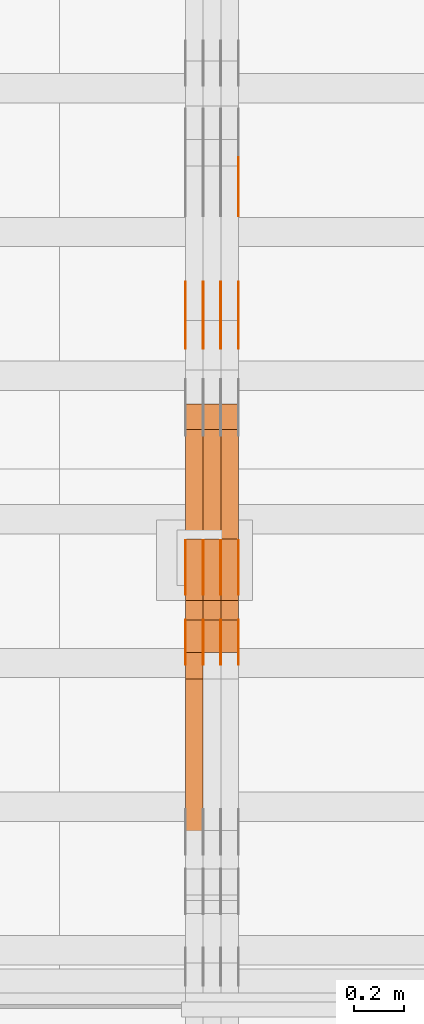
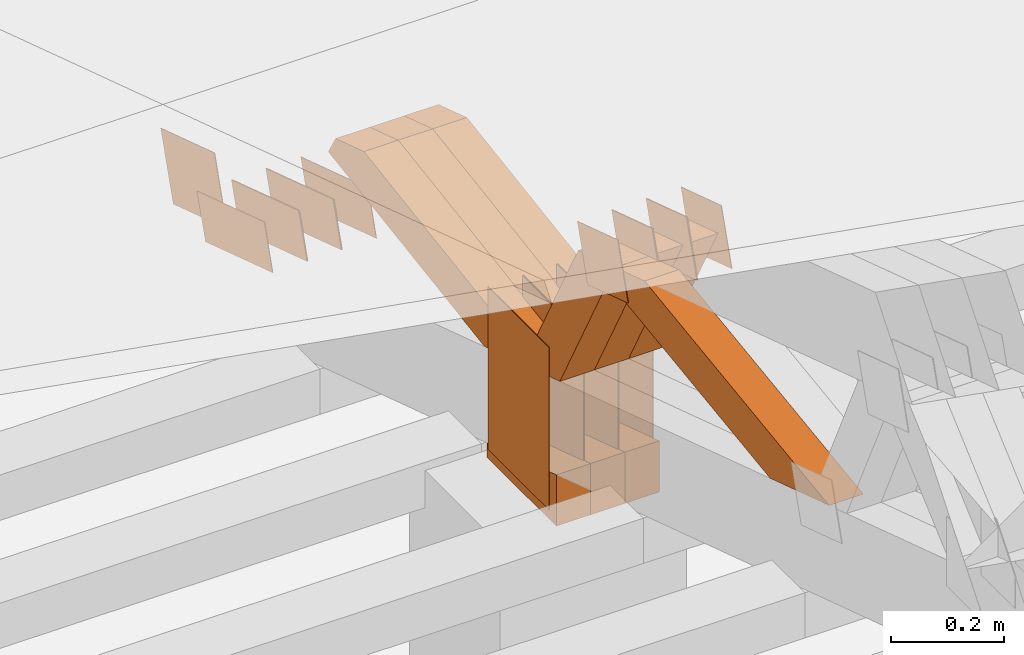
# One storey, part 287 of 385: 29 proxies.
"""IFC2X3 building model written with IfcOpenShell, lengths in millimetres."""

from ifc_helpers import new_model, entity, si_unit, converted_unit, derived_unit, direction, frame, origin, origin_2d_with_axis, place, context, subcontext, project, spatial, polyline, rectangle, outline, extrude, source, transform, mapped, material, type_object, type_shapes, element, save


model = new_model("IFC2X3")

# Units and contexts
model_context = context("Model", 3, precision=0.01, world=origin(), true_north=direction((6.12303176911189e-17, 1.0)))
body_context = subcontext(model_context, "Body", "Model", "MODEL_VIEW")
ifc_project = project(units=[si_unit("LENGTHUNIT", "METRE", prefix="MILLI"), si_unit("AREAUNIT", "SQUARE_METRE"), si_unit("VOLUMEUNIT", "CUBIC_METRE"), converted_unit("PLANEANGLEUNIT", "DEGREE", entity("IfcRatioMeasure", 0.0174532925199433), si_unit("PLANEANGLEUNIT", "RADIAN"), dimensions=[0, 0, 0, 0, 0, 0, 0]), si_unit("MASSUNIT", "GRAM", prefix="KILO"), derived_unit("MASSDENSITYUNIT", [(si_unit("MASSUNIT", "GRAM", prefix="KILO"), 1), (si_unit("LENGTHUNIT", "METRE"), -3)]), si_unit("TIMEUNIT", "SECOND"), si_unit("FREQUENCYUNIT", "HERTZ"), si_unit("THERMODYNAMICTEMPERATUREUNIT", "DEGREE_CELSIUS"), derived_unit("THERMALTRANSMITTANCEUNIT", [(si_unit("MASSUNIT", "GRAM", prefix="KILO"), 1), (si_unit("THERMODYNAMICTEMPERATUREUNIT", "KELVIN"), -1), (si_unit("TIMEUNIT", "SECOND"), -3)]), derived_unit("VOLUMETRICFLOWRATEUNIT", [(si_unit("LENGTHUNIT", "METRE"), 3), (si_unit("TIMEUNIT", "SECOND"), -1)]), si_unit("ELECTRICCURRENTUNIT", "AMPERE"), si_unit("ELECTRICVOLTAGEUNIT", "VOLT"), si_unit("POWERUNIT", "WATT"), si_unit("FORCEUNIT", "NEWTON", prefix="KILO"), si_unit("ILLUMINANCEUNIT", "LUX"), si_unit("LUMINOUSFLUXUNIT", "LUMEN"), si_unit("LUMINOUSINTENSITYUNIT", "CANDELA"), derived_unit("USERDEFINED", [(si_unit("MASSUNIT", "GRAM", prefix="KILO"), -1), (si_unit("LENGTHUNIT", "METRE"), -2), (si_unit("TIMEUNIT", "SECOND"), 3), (si_unit("LUMINOUSFLUXUNIT", "LUMEN"), 1)]), derived_unit("LINEARVELOCITYUNIT", [(si_unit("LENGTHUNIT", "METRE"), 1), (si_unit("TIMEUNIT", "SECOND"), -1)]), si_unit("PRESSUREUNIT", "PASCAL"), derived_unit("USERDEFINED", [(si_unit("LENGTHUNIT", "METRE"), -2), (si_unit("MASSUNIT", "GRAM", prefix="KILO"), 1), (si_unit("TIMEUNIT", "SECOND"), -2)])], contexts=[model_context])

# Site, building, storey
site_placement = place(None, origin())
site = spatial("IfcSite", under=ifc_project, at=site_placement, CompositionType="ELEMENT")
building_placement = place(site_placement, origin())
building = spatial("IfcBuilding", under=site, at=building_placement, CompositionType="ELEMENT")
storey_placement = place(building_placement, origin())
storey = spatial("IfcBuildingStorey", under=building, at=storey_placement, Name="Default", CompositionType="ELEMENT", Elevation=0.0)

# Proxies
ifc_material_1 = material(Name="IfcSurfaceStyle #411286")
building_element_proxy_type_1 = type_object("IfcBuildingElementProxyType", PredefinedType="NOTDEFINED", material=ifc_material_1)
shared_shape_1 = source(origin(), body_context, "Body", "SweptSolid", [
    extrude(outline(polyline([(-125.00031378339, -47.9999612158856), (125.000225258022, -47.9999612158856), (124.999811678525, 47.9999612158856), (-124.999723153156, 47.9999612158856), (-125.00031378339, -47.9999612158856)])), frame((125.000225258022, 48.0000091013474, 0.0), z_axis=(0.0, 0.0, 1.0), x_axis=(-1.0, 0.0, 0.0)), (0.0, 0.0, 1.0), 1.3),
])
type_shapes(building_element_proxy_type_1, [shared_shape_1])
proxy_1_placement = place(building_placement, frame((33386.3, 18456.8597683375, 2657.46691321253), z_axis=(-1.0, 0.0, 0.0), x_axis=(0.0, -0.951056516295124, 0.309016994375039)))
element("IfcBuildingElementProxy", 1, at=proxy_1_placement, inside=storey, type_object=building_element_proxy_type_1, material=ifc_material_1, context=body_context, shape_type="MappedRepresentation", body=[
    mapped(shared_shape_1, transform((0.0, 0.0, 0.0), scale=1.0)),
])
ifc_material_2 = material(Name="IfcSurfaceStyle #411229")
building_element_proxy_type_2 = type_object("IfcBuildingElementProxyType", PredefinedType="NOTDEFINED", material=ifc_material_2)
shared_shape_2 = source(origin(), body_context, "Body", "SweptSolid", [
    extrude(outline(polyline([(-125.00031378339, -47.9999612158856), (125.000225258022, -47.9999612158856), (124.999811678525, 47.9999612158856), (-124.999723153156, 47.9999612158856), (-125.00031378339, -47.9999612158856)])), frame((125.000225258022, 48.0000091013474, 0.0), z_axis=(0.0, 0.0, 1.0), x_axis=(-1.0, 0.0, 0.0)), (0.0, 0.0, 1.0), 1.3),
])
type_shapes(building_element_proxy_type_2, [shared_shape_2])
proxy_2_placement = place(building_placement, frame((33315.0, 18456.8597683375, 2657.46691321253), z_axis=(-1.0, 0.0, 0.0), x_axis=(0.0, -0.951056516295124, 0.309016994375039)))
element("IfcBuildingElementProxy", 2, at=proxy_2_placement, inside=storey, type_object=building_element_proxy_type_2, material=ifc_material_2, context=body_context, shape_type="MappedRepresentation", body=[
    mapped(shared_shape_2, transform((0.0, 0.0, 0.0), scale=1.0)),
])
ifc_material_3 = material(Name="IfcSurfaceStyle #411172")
building_element_proxy_type_3 = type_object("IfcBuildingElementProxyType", PredefinedType="NOTDEFINED", material=ifc_material_3)
shared_shape_3 = source(origin(), body_context, "Body", "SweptSolid", [
    extrude(outline(polyline([(-125.00031378339, -47.9999612158856), (125.000225258022, -47.9999612158856), (124.999811678525, 47.9999612158856), (-124.999723153156, 47.9999612158856), (-125.00031378339, -47.9999612158856)])), frame((125.000225258022, 48.0000091013474, 0.0), z_axis=(0.0, 0.0, 1.0), x_axis=(-1.0, 0.0, 0.0)), (0.0, 0.0, 1.0), 1.3),
])
type_shapes(building_element_proxy_type_3, [shared_shape_3])
proxy_3_placement = place(building_placement, frame((33316.3, 18456.8597683375, 2657.46691321253), z_axis=(-1.0, 0.0, 0.0), x_axis=(0.0, -0.951056516295124, 0.309016994375039)))
element("IfcBuildingElementProxy", 3, at=proxy_3_placement, inside=storey, type_object=building_element_proxy_type_3, material=ifc_material_3, context=body_context, shape_type="MappedRepresentation", body=[
    mapped(shared_shape_3, transform((0.0, 0.0, 0.0), scale=1.0)),
])
ifc_material_4 = material(Name="IfcSurfaceStyle #411115")
building_element_proxy_type_4 = type_object("IfcBuildingElementProxyType", PredefinedType="NOTDEFINED", material=ifc_material_4)
shared_shape_4 = source(origin(), body_context, "Body", "SweptSolid", [
    extrude(outline(polyline([(-125.00031378339, -47.9999612158856), (125.000225258022, -47.9999612158856), (124.999811678525, 47.9999612158856), (-124.999723153156, 47.9999612158856), (-125.00031378339, -47.9999612158856)])), frame((125.000225258022, 48.0000091013474, 0.0), z_axis=(0.0, 0.0, 1.0), x_axis=(-1.0, 0.0, 0.0)), (0.0, 0.0, 1.0), 1.29999999999998),
])
type_shapes(building_element_proxy_type_4, [shared_shape_4])
proxy_4_placement = place(building_placement, frame((33245.0, 18456.8597683375, 2657.46691321253), z_axis=(-1.0, 0.0, 0.0), x_axis=(0.0, -0.951056516295124, 0.309016994375039)))
element("IfcBuildingElementProxy", 4, at=proxy_4_placement, inside=storey, type_object=building_element_proxy_type_4, material=ifc_material_4, context=body_context, shape_type="MappedRepresentation", body=[
    mapped(shared_shape_4, transform((0.0, 0.0, 0.0), scale=1.0)),
])
ifc_material_5 = material(Name="IfcSurfaceStyle #411058")
building_element_proxy_type_5 = type_object("IfcBuildingElementProxyType", PredefinedType="NOTDEFINED", material=ifc_material_5)
shared_shape_5 = source(origin(), body_context, "Body", "SweptSolid", [
    extrude(outline(polyline([(-125.00031378339, -47.9999612158856), (125.000225258022, -47.9999612158856), (124.999811678525, 47.9999612158856), (-124.999723153156, 47.9999612158856), (-125.00031378339, -47.9999612158856)])), frame((125.000225258022, 48.0000091013474, 0.0), z_axis=(0.0, 0.0, 1.0), x_axis=(-1.0, 0.0, 0.0)), (0.0, 0.0, 1.0), 1.29999999999998),
])
type_shapes(building_element_proxy_type_5, [shared_shape_5])
proxy_5_placement = place(building_placement, frame((33246.3, 18456.8597683375, 2657.46691321253), z_axis=(-1.0, 0.0, 0.0), x_axis=(0.0, -0.951056516295124, 0.309016994375039)))
element("IfcBuildingElementProxy", 5, at=proxy_5_placement, inside=storey, type_object=building_element_proxy_type_5, material=ifc_material_5, context=body_context, shape_type="MappedRepresentation", body=[
    mapped(shared_shape_5, transform((0.0, 0.0, 0.0), scale=1.0)),
])
ifc_material_6 = material(Name="IfcSurfaceStyle #411001")
building_element_proxy_type_6 = type_object("IfcBuildingElementProxyType", PredefinedType="NOTDEFINED", material=ifc_material_6)
shared_shape_6 = source(origin(), body_context, "Body", "SweptSolid", [
    extrude(outline(polyline([(-125.00031378339, -47.9999612158856), (125.000225258022, -47.9999612158856), (124.999811678525, 47.9999612158856), (-124.999723153156, 47.9999612158856), (-125.00031378339, -47.9999612158856)])), frame((125.000225258022, 48.0000091013474, 0.0), z_axis=(0.0, 0.0, 1.0), x_axis=(-1.0, 0.0, 0.0)), (0.0, 0.0, 1.0), 1.29999999999998),
])
type_shapes(building_element_proxy_type_6, [shared_shape_6])
proxy_6_placement = place(building_placement, frame((33175.0, 18456.8597683375, 2657.46691321253), z_axis=(-1.0, 0.0, 0.0), x_axis=(0.0, -0.951056516295124, 0.309016994375039)))
element("IfcBuildingElementProxy", 6, at=proxy_6_placement, inside=storey, type_object=building_element_proxy_type_6, material=ifc_material_6, context=body_context, shape_type="MappedRepresentation", body=[
    mapped(shared_shape_6, transform((0.0, 0.0, 0.0), scale=1.0)),
])
ifc_material_7 = material(Name="IfcSurfaceStyle #409576")
building_element_proxy_type_7 = type_object("IfcBuildingElementProxyType", PredefinedType="NOTDEFINED", material=ifc_material_7)
shared_shape_7 = source(origin(), body_context, "Body", "SweptSolid", [
    extrude(outline(polyline([(-99.999796294464, -72.0000050220467), (99.9998768370438, -72.0000050220467), (100.000260677528, 72.0000050220467), (-100.000341220108, 72.0000050220467), (-99.999796294464, -72.0000050220467)])), frame((100.000260677528, 72.0000050220467, 0.0), z_axis=(0.0, 0.0, 1.0), x_axis=(-1.0, 0.0, 0.0)), (0.0, 0.0, 1.0), 1.3),
])
type_shapes(building_element_proxy_type_7, [shared_shape_7])
proxy_7_placement = place(building_placement, frame((33386.3, 18936.3876569477, 2373.90613192527), z_axis=(-1.0, 0.0, 0.0), x_axis=(0.0, -0.951056516295124, 0.309016994375039)))
element("IfcBuildingElementProxy", 7, at=proxy_7_placement, inside=storey, type_object=building_element_proxy_type_7, material=ifc_material_7, context=body_context, shape_type="MappedRepresentation", body=[
    mapped(shared_shape_7, transform((0.0, 0.0, 0.0), scale=1.0)),
])
ifc_material_8 = material(Name="IfcSurfaceStyle #409234")
building_element_proxy_type_8 = type_object("IfcBuildingElementProxyType", PredefinedType="NOTDEFINED", material=ifc_material_8)
shared_shape_8 = source(origin(), body_context, "Body", "SweptSolid", [
    extrude(rectangle(XDim=350.0, YDim=215.999999999984, at=origin_2d_with_axis()), frame((175.0, 108.0, 0.0), z_axis=(0.0, 0.0, 1.0), x_axis=(-1.0, 0.0, 0.0)), (0.0, 0.0, 1.0), 1.29999999999999),
])
type_shapes(building_element_proxy_type_8, [shared_shape_8])
proxy_8_placement = place(building_placement, frame((33386.3, 17459.2939453125, 3165.36425781251), z_axis=(-1.0, 0.0, 0.0), x_axis=(0.0, 0.0, -1.0)))
element("IfcBuildingElementProxy", 8, at=proxy_8_placement, inside=storey, type_object=building_element_proxy_type_8, material=ifc_material_8, context=body_context, shape_type="MappedRepresentation", body=[
    mapped(shared_shape_8, transform((0.0, 0.0, 0.0), scale=1.0)),
])
ifc_material_9 = material(Name="IfcSurfaceStyle #409177")
building_element_proxy_type_9 = type_object("IfcBuildingElementProxyType", PredefinedType="NOTDEFINED", material=ifc_material_9)
shared_shape_9 = source(origin(), body_context, "Body", "SweptSolid", [
    extrude(rectangle(XDim=350.0, YDim=215.999999999984, at=origin_2d_with_axis()), frame((175.0, 108.0, 0.0), z_axis=(0.0, 0.0, 1.0), x_axis=(-1.0, 0.0, 0.0)), (0.0, 0.0, 1.0), 1.29999999999999),
])
type_shapes(building_element_proxy_type_9, [shared_shape_9])
proxy_9_placement = place(building_placement, frame((33315.0, 17459.2939453125, 3165.36425781251), z_axis=(-1.0, 0.0, 0.0), x_axis=(0.0, 0.0, -1.0)))
element("IfcBuildingElementProxy", 9, at=proxy_9_placement, inside=storey, type_object=building_element_proxy_type_9, material=ifc_material_9, context=body_context, shape_type="MappedRepresentation", body=[
    mapped(shared_shape_9, transform((0.0, 0.0, 0.0), scale=1.0)),
])
ifc_material_10 = material(Name="IfcSurfaceStyle #409120")
building_element_proxy_type_10 = type_object("IfcBuildingElementProxyType", PredefinedType="NOTDEFINED", material=ifc_material_10)
shared_shape_10 = source(origin(), body_context, "Body", "SweptSolid", [
    extrude(rectangle(XDim=350.0, YDim=215.999999999984, at=origin_2d_with_axis()), frame((175.0, 108.0, 0.0), z_axis=(0.0, 0.0, 1.0), x_axis=(-1.0, 0.0, 0.0)), (0.0, 0.0, 1.0), 1.29999999999999),
])
type_shapes(building_element_proxy_type_10, [shared_shape_10])
proxy_10_placement = place(building_placement, frame((33316.3, 17459.2939453125, 3165.36425781251), z_axis=(-1.0, 0.0, 0.0), x_axis=(0.0, 0.0, -1.0)))
element("IfcBuildingElementProxy", 10, at=proxy_10_placement, inside=storey, type_object=building_element_proxy_type_10, material=ifc_material_10, context=body_context, shape_type="MappedRepresentation", body=[
    mapped(shared_shape_10, transform((0.0, 0.0, 0.0), scale=1.0)),
])
ifc_material_11 = material(Name="IfcSurfaceStyle #409063")
building_element_proxy_type_11 = type_object("IfcBuildingElementProxyType", PredefinedType="NOTDEFINED", material=ifc_material_11)
shared_shape_11 = source(origin(), body_context, "Body", "SweptSolid", [
    extrude(rectangle(XDim=350.0, YDim=215.999999999984, at=origin_2d_with_axis()), frame((175.0, 108.0, 0.0), z_axis=(0.0, 0.0, 1.0), x_axis=(-1.0, 0.0, 0.0)), (0.0, 0.0, 1.0), 1.29999999999998),
])
type_shapes(building_element_proxy_type_11, [shared_shape_11])
proxy_11_placement = place(building_placement, frame((33245.0, 17459.2939453125, 3165.36425781251), z_axis=(-1.0, 0.0, 0.0), x_axis=(0.0, 0.0, -1.0)))
element("IfcBuildingElementProxy", 11, at=proxy_11_placement, inside=storey, type_object=building_element_proxy_type_11, material=ifc_material_11, context=body_context, shape_type="MappedRepresentation", body=[
    mapped(shared_shape_11, transform((0.0, 0.0, 0.0), scale=1.0)),
])
ifc_material_12 = material(Name="IfcSurfaceStyle #409006")
building_element_proxy_type_12 = type_object("IfcBuildingElementProxyType", PredefinedType="NOTDEFINED", material=ifc_material_12)
shared_shape_12 = source(origin(), body_context, "Body", "SweptSolid", [
    extrude(rectangle(XDim=350.0, YDim=215.999999999984, at=origin_2d_with_axis()), frame((175.0, 108.0, 0.0), z_axis=(0.0, 0.0, 1.0), x_axis=(-1.0, 0.0, 0.0)), (0.0, 0.0, 1.0), 1.29999999999998),
])
type_shapes(building_element_proxy_type_12, [shared_shape_12])
proxy_12_placement = place(building_placement, frame((33246.3, 17459.2939453125, 3165.36425781251), z_axis=(-1.0, 0.0, 0.0), x_axis=(0.0, 0.0, -1.0)))
element("IfcBuildingElementProxy", 12, at=proxy_12_placement, inside=storey, type_object=building_element_proxy_type_12, material=ifc_material_12, context=body_context, shape_type="MappedRepresentation", body=[
    mapped(shared_shape_12, transform((0.0, 0.0, 0.0), scale=1.0)),
])
ifc_material_13 = material(Name="IfcSurfaceStyle #408949")
building_element_proxy_type_13 = type_object("IfcBuildingElementProxyType", PredefinedType="NOTDEFINED", material=ifc_material_13)
shared_shape_13 = source(origin(), body_context, "Body", "SweptSolid", [
    extrude(rectangle(XDim=350.0, YDim=215.999999999984, at=origin_2d_with_axis()), frame((175.0, 108.0, 0.0), z_axis=(0.0, 0.0, 1.0), x_axis=(-1.0, 0.0, 0.0)), (0.0, 0.0, 1.0), 1.29999999999998),
])
type_shapes(building_element_proxy_type_13, [shared_shape_13])
proxy_13_placement = place(building_placement, frame((33175.0, 17459.2939453125, 3165.36425781251), z_axis=(-1.0, 0.0, 0.0), x_axis=(0.0, 0.0, -1.0)))
element("IfcBuildingElementProxy", 13, at=proxy_13_placement, inside=storey, type_object=building_element_proxy_type_13, material=ifc_material_13, context=body_context, shape_type="MappedRepresentation", body=[
    mapped(shared_shape_13, transform((0.0, 0.0, 0.0), scale=1.0)),
])
ifc_material_14 = material(Name="IfcSurfaceStyle #405814")
building_element_proxy_type_14 = type_object("IfcBuildingElementProxyType", PredefinedType="NOTDEFINED", material=ifc_material_14)
shared_shape_14 = source(origin(), body_context, "Body", "SweptSolid", [
    extrude(outline(polyline([(-74.9998605591058, -59.9999264677524), (74.999875428623, -59.9999264677524), (74.9998605591068, 59.9999264677524), (-74.9998754286239, 59.9999264677524), (-74.9998605591058, -59.9999264677524)])), frame((75.0002460484325, 60.0000016373508, 0.0), z_axis=(0.0, 0.0, 1.0), x_axis=(-1.0, 0.0, 0.0)), (0.0, 0.0, 1.0), 1.3),
])
type_shapes(building_element_proxy_type_14, [shared_shape_14])
proxy_14_placement = place(building_placement, frame((33386.3, 17107.0599369346, 3383.82825001787), z_axis=(-1.0, 0.0, 0.0), x_axis=(0.0, -0.951056516295154, 0.309016994374948)))
element("IfcBuildingElementProxy", 14, at=proxy_14_placement, inside=storey, type_object=building_element_proxy_type_14, material=ifc_material_14, context=body_context, shape_type="MappedRepresentation", body=[
    mapped(shared_shape_14, transform((0.0, 0.0, 0.0), scale=1.0)),
])
ifc_material_15 = material(Name="IfcSurfaceStyle #405757")
building_element_proxy_type_15 = type_object("IfcBuildingElementProxyType", PredefinedType="NOTDEFINED", material=ifc_material_15)
shared_shape_15 = source(origin(), body_context, "Body", "SweptSolid", [
    extrude(outline(polyline([(-74.9998605591058, -59.9999264677524), (74.999875428623, -59.9999264677524), (74.9998605591068, 59.9999264677524), (-74.9998754286239, 59.9999264677524), (-74.9998605591058, -59.9999264677524)])), frame((75.0002460484325, 60.0000016373508, 0.0), z_axis=(0.0, 0.0, 1.0), x_axis=(-1.0, 0.0, 0.0)), (0.0, 0.0, 1.0), 1.3),
])
type_shapes(building_element_proxy_type_15, [shared_shape_15])
proxy_15_placement = place(building_placement, frame((33315.0, 17107.0599369346, 3383.82825001787), z_axis=(-1.0, 0.0, 0.0), x_axis=(0.0, -0.951056516295154, 0.309016994374948)))
element("IfcBuildingElementProxy", 15, at=proxy_15_placement, inside=storey, type_object=building_element_proxy_type_15, material=ifc_material_15, context=body_context, shape_type="MappedRepresentation", body=[
    mapped(shared_shape_15, transform((0.0, 0.0, 0.0), scale=1.0)),
])
ifc_material_16 = material(Name="IfcSurfaceStyle #405700")
building_element_proxy_type_16 = type_object("IfcBuildingElementProxyType", PredefinedType="NOTDEFINED", material=ifc_material_16)
shared_shape_16 = source(origin(), body_context, "Body", "SweptSolid", [
    extrude(outline(polyline([(-74.9998605591058, -59.9999264677524), (74.999875428623, -59.9999264677524), (74.9998605591068, 59.9999264677524), (-74.9998754286239, 59.9999264677524), (-74.9998605591058, -59.9999264677524)])), frame((75.0002460484325, 60.0000016373508, 0.0), z_axis=(0.0, 0.0, 1.0), x_axis=(-1.0, 0.0, 0.0)), (0.0, 0.0, 1.0), 1.3),
])
type_shapes(building_element_proxy_type_16, [shared_shape_16])
proxy_16_placement = place(building_placement, frame((33316.3, 17107.0599369346, 3383.82825001787), z_axis=(-1.0, 0.0, 0.0), x_axis=(0.0, -0.951056516295154, 0.309016994374948)))
element("IfcBuildingElementProxy", 16, at=proxy_16_placement, inside=storey, type_object=building_element_proxy_type_16, material=ifc_material_16, context=body_context, shape_type="MappedRepresentation", body=[
    mapped(shared_shape_16, transform((0.0, 0.0, 0.0), scale=1.0)),
])
ifc_material_17 = material(Name="IfcSurfaceStyle #405643")
building_element_proxy_type_17 = type_object("IfcBuildingElementProxyType", PredefinedType="NOTDEFINED", material=ifc_material_17)
shared_shape_17 = source(origin(), body_context, "Body", "SweptSolid", [
    extrude(outline(polyline([(-74.9998605591058, -59.9999264677524), (74.999875428623, -59.9999264677524), (74.9998605591068, 59.9999264677524), (-74.9998754286239, 59.9999264677524), (-74.9998605591058, -59.9999264677524)])), frame((75.0002460484325, 60.0000016373508, 0.0), z_axis=(0.0, 0.0, 1.0), x_axis=(-1.0, 0.0, 0.0)), (0.0, 0.0, 1.0), 1.29999999999999),
])
type_shapes(building_element_proxy_type_17, [shared_shape_17])
proxy_17_placement = place(building_placement, frame((33245.0, 17107.0599369346, 3383.82825001787), z_axis=(-1.0, 0.0, 0.0), x_axis=(0.0, -0.951056516295154, 0.309016994374948)))
element("IfcBuildingElementProxy", 17, at=proxy_17_placement, inside=storey, type_object=building_element_proxy_type_17, material=ifc_material_17, context=body_context, shape_type="MappedRepresentation", body=[
    mapped(shared_shape_17, transform((0.0, 0.0, 0.0), scale=1.0)),
])
ifc_material_18 = material(Name="IfcSurfaceStyle #405586")
building_element_proxy_type_18 = type_object("IfcBuildingElementProxyType", PredefinedType="NOTDEFINED", material=ifc_material_18)
shared_shape_18 = source(origin(), body_context, "Body", "SweptSolid", [
    extrude(outline(polyline([(-74.9998605591058, -59.9999264677524), (74.999875428623, -59.9999264677524), (74.9998605591068, 59.9999264677524), (-74.9998754286239, 59.9999264677524), (-74.9998605591058, -59.9999264677524)])), frame((75.0002460484325, 60.0000016373508, 0.0), z_axis=(0.0, 0.0, 1.0), x_axis=(-1.0, 0.0, 0.0)), (0.0, 0.0, 1.0), 1.29999999999999),
])
type_shapes(building_element_proxy_type_18, [shared_shape_18])
proxy_18_placement = place(building_placement, frame((33246.3, 17107.0599369346, 3383.82825001787), z_axis=(-1.0, 0.0, 0.0), x_axis=(0.0, -0.951056516295154, 0.309016994374948)))
element("IfcBuildingElementProxy", 18, at=proxy_18_placement, inside=storey, type_object=building_element_proxy_type_18, material=ifc_material_18, context=body_context, shape_type="MappedRepresentation", body=[
    mapped(shared_shape_18, transform((0.0, 0.0, 0.0), scale=1.0)),
])
ifc_material_19 = material(Name="IfcSurfaceStyle #405529")
building_element_proxy_type_19 = type_object("IfcBuildingElementProxyType", PredefinedType="NOTDEFINED", material=ifc_material_19)
shared_shape_19 = source(origin(), body_context, "Body", "SweptSolid", [
    extrude(outline(polyline([(-74.9998605591058, -59.9999264677524), (74.999875428623, -59.9999264677524), (74.9998605591068, 59.9999264677524), (-74.9998754286239, 59.9999264677524), (-74.9998605591058, -59.9999264677524)])), frame((75.0002460484325, 60.0000016373508, 0.0), z_axis=(0.0, 0.0, 1.0), x_axis=(-1.0, 0.0, 0.0)), (0.0, 0.0, 1.0), 1.29999999999999),
])
type_shapes(building_element_proxy_type_19, [shared_shape_19])
proxy_19_placement = place(building_placement, frame((33175.0, 17107.0599369346, 3383.82825001787), z_axis=(-1.0, 0.0, 0.0), x_axis=(0.0, -0.951056516295154, 0.309016994374948)))
element("IfcBuildingElementProxy", 19, at=proxy_19_placement, inside=storey, type_object=building_element_proxy_type_19, material=ifc_material_19, context=body_context, shape_type="MappedRepresentation", body=[
    mapped(shared_shape_19, transform((0.0, 0.0, 0.0), scale=1.0)),
])
ifc_material_20 = material(Name="IfcSurfaceStyle #397525")
building_element_proxy_type_20 = type_object("IfcBuildingElementProxyType", Name="T1-E1 397523", PredefinedType="NOTDEFINED", material=ifc_material_20)
shared_shape_20 = source(origin(), body_context, "Body", "SweptSolid", [
    extrude(outline(polyline([(4.4675903320374, -122.500000000001), (35.3350219726624, -122.500000000001), (35.3350219726501, 122.500000000001), (-75.1376342773499, 122.500000000001), (4.4675903320374, -122.500000000001)])), frame((35.3350219726624, 122.50000005215, 0.0), z_axis=(0.0, 0.0, 1.0), x_axis=(-1.0, 0.0, 0.0)), (0.0, 0.0, 1.0), 70.0),
])
type_shapes(building_element_proxy_type_20, [shared_shape_20])
proxy_20_placement = place(building_placement, frame((33385.0, 17220.0, 2794.30932617186), z_axis=(-1.0, 0.0, 0.0), x_axis=(0.0, 0.0, 1.0)))
element("IfcBuildingElementProxy", 20, at=proxy_20_placement, inside=storey, type_object=building_element_proxy_type_20, material=ifc_material_20, Name="T1-E1", context=body_context, shape_type="MappedRepresentation", body=[
    mapped(shared_shape_20, transform((0.0, 0.0, 0.0), scale=1.0)),
])
ifc_material_21 = material(Name="IfcSurfaceStyle #397468")
building_element_proxy_type_21 = type_object("IfcBuildingElementProxyType", Name="T1-E1 397466", PredefinedType="NOTDEFINED", material=ifc_material_21)
shared_shape_21 = source(origin(), body_context, "Body", "SweptSolid", [
    extrude(outline(polyline([(4.4675903320374, -122.500000000001), (35.3350219726624, -122.500000000001), (35.3350219726501, 122.500000000001), (-75.1376342773499, 122.500000000001), (4.4675903320374, -122.500000000001)])), frame((35.3350219726624, 122.50000005215, 0.0), z_axis=(0.0, 0.0, 1.0), x_axis=(-1.0, 0.0, 0.0)), (0.0, 0.0, 1.0), 70.0),
])
type_shapes(building_element_proxy_type_21, [shared_shape_21])
proxy_21_placement = place(building_placement, frame((33315.0, 17220.0, 2794.30932617186), z_axis=(-1.0, 0.0, 0.0), x_axis=(0.0, 0.0, 1.0)))
element("IfcBuildingElementProxy", 21, at=proxy_21_placement, inside=storey, type_object=building_element_proxy_type_21, material=ifc_material_21, Name="T1-E1", context=body_context, shape_type="MappedRepresentation", body=[
    mapped(shared_shape_21, transform((0.0, 0.0, 0.0), scale=1.0)),
])
ifc_material_22 = material(Name="IfcSurfaceStyle #397411")
building_element_proxy_type_22 = type_object("IfcBuildingElementProxyType", Name="T1-E1 397409", PredefinedType="NOTDEFINED", material=ifc_material_22)
shared_shape_22 = source(origin(), body_context, "Body", "SweptSolid", [
    extrude(outline(polyline([(4.4675903320374, -122.500000000001), (35.3350219726624, -122.500000000001), (35.3350219726501, 122.500000000001), (-75.1376342773499, 122.500000000001), (4.4675903320374, -122.500000000001)])), frame((35.3350219726624, 122.50000005215, 0.0), z_axis=(0.0, 0.0, 1.0), x_axis=(-1.0, 0.0, 0.0)), (0.0, 0.0, 1.0), 70.0),
])
type_shapes(building_element_proxy_type_22, [shared_shape_22])
proxy_22_placement = place(building_placement, frame((33245.0, 17220.0, 2794.30932617186), z_axis=(-1.0, 0.0, 0.0), x_axis=(0.0, 0.0, 1.0)))
element("IfcBuildingElementProxy", 22, at=proxy_22_placement, inside=storey, type_object=building_element_proxy_type_22, material=ifc_material_22, Name="T1-E1", context=body_context, shape_type="MappedRepresentation", body=[
    mapped(shared_shape_22, transform((0.0, 0.0, 0.0), scale=1.0)),
])
ifc_material_23 = material(Name="IfcSurfaceStyle #396034")
building_element_proxy_type_23 = type_object("IfcBuildingElementProxyType", Name="T1-W8 396032", PredefinedType="NOTDEFINED", material=ifc_material_23)
shared_shape_23 = source(origin(), body_context, "Body", "SweptSolid", [
    extrude(outline(polyline([(-476.725263324644, -47.5001051695965), (180.672765845439, -47.5001051695965), (279.11020091716, -1.03605560390907e-06), (296.793624402619, 47.5001056876243), (-279.851327840575, 47.5001056876243), (-476.725263324644, -47.5001051695965)])), frame((296.793624402619, 47.5001056876243, 0.0), z_axis=(0.0, 0.0, 1.0), x_axis=(-1.0, 0.0, 0.0)), (0.0, 0.0, 1.0), 70.0),
])
type_shapes(building_element_proxy_type_23, [shared_shape_23])
proxy_23_placement = place(building_placement, frame((33245.0, 17036.40625, 3432.97192382813), z_axis=(-1.0, 0.0, 0.0), x_axis=(0.0, -0.990844046556832, -0.135011389900564)))
element("IfcBuildingElementProxy", 23, at=proxy_23_placement, inside=storey, type_object=building_element_proxy_type_23, material=ifc_material_23, Name="T1-W8", context=body_context, shape_type="MappedRepresentation", body=[
    mapped(shared_shape_23, transform((0.0, 0.0, 0.0), scale=1.0)),
])
ifc_material_24 = material(Name="IfcSurfaceStyle #395770")
building_element_proxy_type_24 = type_object("IfcBuildingElementProxyType", Name="T1-W39 395768", PredefinedType="NOTDEFINED", material=ifc_material_24)
shared_shape_24 = source(origin(), body_context, "Body", "SweptSolid", [
    extrude(outline(polyline([(-191.519946663886, -47.499928106579), (188.32936223763, -47.499928106579), (171.597440144109, 0.000249483340993841), (122.102882529753, 47.4998033649085), (-290.509738247605, 47.4998033649085), (-191.519946663886, -47.499928106579)])), frame((188.329593252001, 47.499957247623, 0.0), z_axis=(0.0, 0.0, 1.0), x_axis=(-1.0, 0.0, 0.0)), (0.0, 0.0, 1.0), 70.0),
])
type_shapes(building_element_proxy_type_24, [shared_shape_24])
proxy_24_placement = place(building_placement, frame((33385.0, 17238.5876916597, 3055.56121424762), z_axis=(-1.0, 0.0, 0.0), x_axis=(0.0, -0.472216932390777, 0.881482370080902)))
element("IfcBuildingElementProxy", 24, at=proxy_24_placement, inside=storey, type_object=building_element_proxy_type_24, material=ifc_material_24, Name="T1-W39", context=body_context, shape_type="MappedRepresentation", body=[
    mapped(shared_shape_24, transform((0.0, 0.0, 0.0), scale=1.0)),
])
ifc_material_25 = material(Name="IfcSurfaceStyle #395704")
building_element_proxy_type_25 = type_object("IfcBuildingElementProxyType", Name="T1-W39 395702", PredefinedType="NOTDEFINED", material=ifc_material_25)
shared_shape_25 = source(origin(), body_context, "Body", "SweptSolid", [
    extrude(outline(polyline([(-191.519946663886, -47.499928106579), (188.32936223763, -47.499928106579), (171.597440144109, 0.000249483340993841), (122.102882529753, 47.4998033649085), (-290.509738247605, 47.4998033649085), (-191.519946663886, -47.499928106579)])), frame((188.329593252001, 47.499957247623, 0.0), z_axis=(0.0, 0.0, 1.0), x_axis=(-1.0, 0.0, 0.0)), (0.0, 0.0, 1.0), 70.0),
])
type_shapes(building_element_proxy_type_25, [shared_shape_25])
proxy_25_placement = place(building_placement, frame((33315.0, 17238.5876916597, 3055.56121424762), z_axis=(-1.0, 0.0, 0.0), x_axis=(0.0, -0.472216932390777, 0.881482370080902)))
element("IfcBuildingElementProxy", 25, at=proxy_25_placement, inside=storey, type_object=building_element_proxy_type_25, material=ifc_material_25, Name="T1-W39", context=body_context, shape_type="MappedRepresentation", body=[
    mapped(shared_shape_25, transform((0.0, 0.0, 0.0), scale=1.0)),
])
ifc_material_26 = material(Name="IfcSurfaceStyle #395638")
building_element_proxy_type_26 = type_object("IfcBuildingElementProxyType", Name="T1-W39 395636", PredefinedType="NOTDEFINED", material=ifc_material_26)
shared_shape_26 = source(origin(), body_context, "Body", "SweptSolid", [
    extrude(outline(polyline([(-191.519946663886, -47.499928106579), (188.32936223763, -47.499928106579), (171.597440144109, 0.000249483340993841), (122.102882529753, 47.4998033649085), (-290.509738247605, 47.4998033649085), (-191.519946663886, -47.499928106579)])), frame((188.329593252001, 47.499957247623, 0.0), z_axis=(0.0, 0.0, 1.0), x_axis=(-1.0, 0.0, 0.0)), (0.0, 0.0, 1.0), 70.0),
])
type_shapes(building_element_proxy_type_26, [shared_shape_26])
proxy_26_placement = place(building_placement, frame((33245.0, 17238.5876916597, 3055.56121424762), z_axis=(-1.0, 0.0, 0.0), x_axis=(0.0, -0.472216932390777, 0.881482370080902)))
element("IfcBuildingElementProxy", 26, at=proxy_26_placement, inside=storey, type_object=building_element_proxy_type_26, material=ifc_material_26, Name="T1-W39", context=body_context, shape_type="MappedRepresentation", body=[
    mapped(shared_shape_26, transform((0.0, 0.0, 0.0), scale=1.0)),
])
ifc_material_27 = material(Name="IfcSurfaceStyle #395374")
building_element_proxy_type_27 = type_object("IfcBuildingElementProxyType", Name="T1-W10 395372", PredefinedType="NOTDEFINED", material=ifc_material_27)
shared_shape_27 = source(origin(), body_context, "Body", "SweptSolid", [
    extrude(outline(polyline([(-459.546036710757, -47.5000436364511), (174.689450869018, -47.5000436364511), (268.831081103959, 0.00011114562912502), (287.286350706789, 47.4999880636365), (-271.260845969009, 47.4999880636366), (-459.546036710757, -47.5000436364511)])), frame((287.286768781132, 47.5001637448091, 0.0), z_axis=(0.0, 0.0, 1.0), x_axis=(-1.0, 0.0, 0.0)), (0.0, 0.0, 1.0), 70.0),
])
type_shapes(building_element_proxy_type_27, [shared_shape_27])
proxy_27_placement = place(building_placement, frame((33385.0, 18025.1410649788, 3112.76453857986), z_axis=(-1.0, 0.0, 0.0), x_axis=(0.0, -0.988299196256916, -0.152527698068035)))
element("IfcBuildingElementProxy", 27, at=proxy_27_placement, inside=storey, type_object=building_element_proxy_type_27, material=ifc_material_27, Name="T1-W10", context=body_context, shape_type="MappedRepresentation", body=[
    mapped(shared_shape_27, transform((0.0, 0.0, 0.0), scale=1.0)),
])
ifc_material_28 = material(Name="IfcSurfaceStyle #395308")
building_element_proxy_type_28 = type_object("IfcBuildingElementProxyType", Name="T1-W10 395306", PredefinedType="NOTDEFINED", material=ifc_material_28)
shared_shape_28 = source(origin(), body_context, "Body", "SweptSolid", [
    extrude(outline(polyline([(-459.546036710757, -47.5000436364511), (174.689450869018, -47.5000436364511), (268.831081103959, 0.00011114562912502), (287.286350706789, 47.4999880636365), (-271.260845969009, 47.4999880636366), (-459.546036710757, -47.5000436364511)])), frame((287.286768781132, 47.5001637448091, 0.0), z_axis=(0.0, 0.0, 1.0), x_axis=(-1.0, 0.0, 0.0)), (0.0, 0.0, 1.0), 70.0),
])
type_shapes(building_element_proxy_type_28, [shared_shape_28])
proxy_28_placement = place(building_placement, frame((33315.0, 18025.1410649788, 3112.76453857986), z_axis=(-1.0, 0.0, 0.0), x_axis=(0.0, -0.988299196256916, -0.152527698068035)))
element("IfcBuildingElementProxy", 28, at=proxy_28_placement, inside=storey, type_object=building_element_proxy_type_28, material=ifc_material_28, Name="T1-W10", context=body_context, shape_type="MappedRepresentation", body=[
    mapped(shared_shape_28, transform((0.0, 0.0, 0.0), scale=1.0)),
])
ifc_material_29 = material(Name="IfcSurfaceStyle #395242")
building_element_proxy_type_29 = type_object("IfcBuildingElementProxyType", Name="T1-W10 395240", PredefinedType="NOTDEFINED", material=ifc_material_29)
shared_shape_29 = source(origin(), body_context, "Body", "SweptSolid", [
    extrude(outline(polyline([(-459.546036710757, -47.5000436364511), (174.689450869018, -47.5000436364511), (268.831081103959, 0.00011114562912502), (287.286350706789, 47.4999880636365), (-271.260845969009, 47.4999880636366), (-459.546036710757, -47.5000436364511)])), frame((287.286768781132, 47.5001637448091, 0.0), z_axis=(0.0, 0.0, 1.0), x_axis=(-1.0, 0.0, 0.0)), (0.0, 0.0, 1.0), 70.0),
])
type_shapes(building_element_proxy_type_29, [shared_shape_29])
proxy_29_placement = place(building_placement, frame((33245.0, 18025.1410649788, 3112.76453857986), z_axis=(-1.0, 0.0, 0.0), x_axis=(0.0, -0.988299196256916, -0.152527698068035)))
element("IfcBuildingElementProxy", 29, at=proxy_29_placement, inside=storey, type_object=building_element_proxy_type_29, material=ifc_material_29, Name="T1-W10", context=body_context, shape_type="MappedRepresentation", body=[
    mapped(shared_shape_29, transform((0.0, 0.0, 0.0), scale=1.0)),
])

save(model, "model.ifc")
